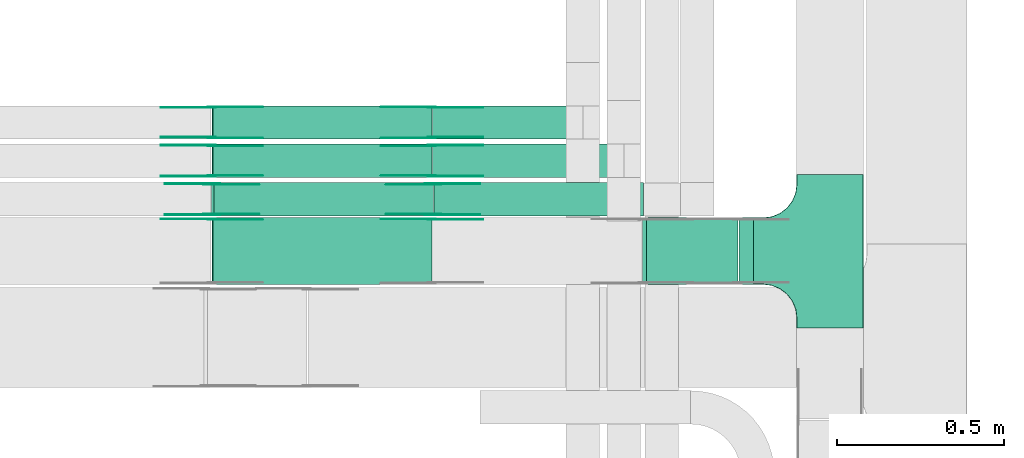
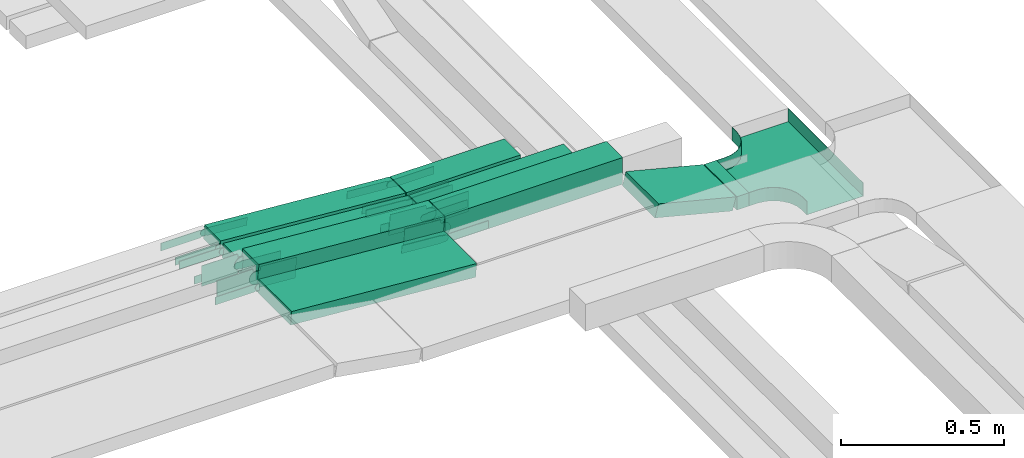
# One storey, part 5 of 19: 29 flow fittings, 9 flow segments.
"""IFC2X3 building model written with IfcOpenShell, lengths in millimetres."""

from ifc_helpers import new_model, entity, si_unit, converted_unit, derived_unit, direction, frame, frame_2d, origin, origin_2d_with_axis, place, context, subcontext, project, spatial, polyline, circle_curve, parameter, trimmed, segment, composite_curve, rectangle, outline, extrude, faceted_brep, source, transform, mapped, material, type_object, type_shapes, element, save


model = new_model("IFC2X3")

# Units and contexts
model_context = context("Model", 3, precision=0.01, world=origin(), true_north=direction((6.12303176911189e-17, 1.0)))
body_context = subcontext(model_context, "Body", "Model", "MODEL_VIEW")
ifc_project = project(units=[si_unit("LENGTHUNIT", "METRE", prefix="MILLI"), si_unit("AREAUNIT", "SQUARE_METRE"), si_unit("VOLUMEUNIT", "CUBIC_METRE"), converted_unit("PLANEANGLEUNIT", "DEGREE", entity("IfcRatioMeasure", 0.0174532925199433), si_unit("PLANEANGLEUNIT", "RADIAN"), dimensions=[0, 0, 0, 0, 0, 0, 0]), si_unit("MASSUNIT", "GRAM", prefix="KILO"), derived_unit("MASSDENSITYUNIT", [(si_unit("MASSUNIT", "GRAM", prefix="KILO"), 1), (si_unit("LENGTHUNIT", "METRE"), -3)]), derived_unit("MOMENTOFINERTIAUNIT", [(si_unit("LENGTHUNIT", "METRE"), 4)]), si_unit("TIMEUNIT", "SECOND"), si_unit("FREQUENCYUNIT", "HERTZ"), si_unit("THERMODYNAMICTEMPERATUREUNIT", "DEGREE_CELSIUS"), derived_unit("THERMALTRANSMITTANCEUNIT", [(si_unit("MASSUNIT", "GRAM", prefix="KILO"), 1), (si_unit("THERMODYNAMICTEMPERATUREUNIT", "KELVIN"), -1), (si_unit("TIMEUNIT", "SECOND"), -3)]), derived_unit("VOLUMETRICFLOWRATEUNIT", [(si_unit("LENGTHUNIT", "METRE"), 3), (si_unit("TIMEUNIT", "SECOND"), -1)]), derived_unit("MASSFLOWRATEUNIT", [(si_unit("MASSUNIT", "GRAM", prefix="KILO"), 1), (si_unit("TIMEUNIT", "SECOND"), -1)]), derived_unit("ROTATIONALFREQUENCYUNIT", [(si_unit("TIMEUNIT", "SECOND"), -1)]), si_unit("ELECTRICCURRENTUNIT", "AMPERE"), si_unit("ELECTRICVOLTAGEUNIT", "VOLT"), si_unit("POWERUNIT", "WATT"), si_unit("FORCEUNIT", "NEWTON", prefix="KILO"), si_unit("ILLUMINANCEUNIT", "LUX"), si_unit("LUMINOUSFLUXUNIT", "LUMEN"), si_unit("LUMINOUSINTENSITYUNIT", "CANDELA"), derived_unit("USERDEFINED", [(si_unit("MASSUNIT", "GRAM", prefix="KILO"), -1), (si_unit("LENGTHUNIT", "METRE"), -2), (si_unit("TIMEUNIT", "SECOND"), 3), (si_unit("LUMINOUSFLUXUNIT", "LUMEN"), 1)]), derived_unit("LINEARVELOCITYUNIT", [(si_unit("LENGTHUNIT", "METRE"), 1), (si_unit("TIMEUNIT", "SECOND"), -1)]), si_unit("PRESSUREUNIT", "PASCAL"), derived_unit("USERDEFINED", [(si_unit("LENGTHUNIT", "METRE"), -2), (si_unit("MASSUNIT", "GRAM", prefix="KILO"), 1), (si_unit("TIMEUNIT", "SECOND"), -2)]), derived_unit("LINEARFORCEUNIT", [(si_unit("MASSUNIT", "GRAM", prefix="KILO"), 1), (si_unit("LENGTHUNIT", "METRE"), 1), (si_unit("TIMEUNIT", "SECOND"), -2), (si_unit("LENGTHUNIT", "METRE"), -1)]), derived_unit("PLANARFORCEUNIT", [(si_unit("MASSUNIT", "GRAM", prefix="KILO"), 1), (si_unit("LENGTHUNIT", "METRE"), 1), (si_unit("TIMEUNIT", "SECOND"), -2), (si_unit("LENGTHUNIT", "METRE"), -2)])], contexts=[model_context])

# Site, building, storey
site_placement = place(None, frame((0.0, -0.00077364408347762, 0.0)))
site = spatial("IfcSite", under=ifc_project, at=site_placement, CompositionType="ELEMENT")
building_placement = place(site_placement, origin())
building = spatial("IfcBuilding", under=site, at=building_placement, CompositionType="ELEMENT")
storey_placement = place(building_placement, frame((0.0, 0.0, 12000.0)))
storey = spatial("IfcBuildingStorey", under=building, at=storey_placement, CompositionType="ELEMENT", Elevation=12000.0)

# Flow segments
cable_carrier_segment_type = type_object("IfcCableCarrierSegmentType", PredefinedType="CABLETRAYSEGMENT")
flow_segment_1_placement = place(storey_placement, frame((16927.6135747369, 12994.157206347, 2800.0)))
element("IfcFlowSegment", 1, at=flow_segment_1_placement, inside=storey, type_object=cable_carrier_segment_type, context=body_context, shape_type="SweptSolid", body=[
    extrude(rectangle(XDim=404.371545128235, YDim=99.9999999999989, at=frame_2d((0.0, 1.08357767203415e-12), x_axis=(1.0, 0.0))), frame((202.185772564118, 50.0, 0.0), z_axis=(0.0, 0.0, 1.0), x_axis=(-1.0, 0.0, 0.0)), (0.0, 0.0, 1.0), 50.0000000000038),
])
flow_segment_2_placement = place(storey_placement, frame((16932.3345533932, 12764.1572065447, 2799.7143217357)))
element("IfcFlowSegment", 2, at=flow_segment_2_placement, inside=storey, type_object=cable_carrier_segment_type, context=body_context, shape_type="SweptSolid", body=[
    extrude(rectangle(XDim=627.939695827148, YDim=99.9999996045748, at=frame_2d((0.0, -1.08357767203415e-12), x_axis=(1.0, 0.0))), frame((314.015310813834, 49.9999998023004, 0.14284181830775), z_axis=(-0.000454953936678616, 0.0, 0.999999896508452), x_axis=(-0.999999896508452, 0.0, -0.000454953936678616)), (0.0, 0.0, 1.0), 99.9999996045756),
])
flow_segment_3_placement = place(storey_placement, frame((16266.5458271958, 12994.157206347, 2800.23031718028)))
element("IfcFlowSegment", 3, at=flow_segment_3_placement, inside=storey, type_object=cable_carrier_segment_type, context=body_context, shape_type="SweptSolid", body=[
    extrude(rectangle(XDim=50.0, YDim=99.9999999999989, at=frame_2d((-2.16360263038951e-12, 0.0), x_axis=(0.0, 1.0))), frame((1.8908897636833, 50.0, 74.6109774865328), z_axis=(0.997135526115965, 0.0, -0.0756355905472889), x_axis=(0.0, 1.0, 0.0)), (0.0, 0.0, 1.0), 656.867870987157),
])
flow_segment_4_placement = place(storey_placement, frame((16927.613574737, 12879.4401033081, 2800.0)))
element("IfcFlowSegment", 4, at=flow_segment_4_placement, inside=storey, type_object=cable_carrier_segment_type, context=body_context, shape_type="SweptSolid", body=[
    extrude(rectangle(XDim=548.189497841086, YDim=99.9999999999989, at=frame_2d((2.1600499167107e-12, -1.08357767203415e-12), x_axis=(1.0, 0.0))), frame((274.094748920545, 50.0, 0.0)), (0.0, 0.0, 1.0), 49.9999999999995),
])
flow_segment_5_placement = place(storey_placement, frame((17845.7963262602, 12558.7956510923, 2727.85030390841)))
element("IfcFlowSegment", 5, at=flow_segment_5_placement, inside=storey, type_object=cable_carrier_segment_type, context=body_context, shape_type="SweptSolid", body=[
    extrude(rectangle(XDim=42.7911006156176, YDim=200.000000000002, at=origin_2d_with_axis()), frame((21.3955503078175, 100.0, 0.0), z_axis=(0.0, 0.0, 1.0), x_axis=(-1.0, 0.0, 0.0)), (0.0, 0.0, 1.0), 49.9999999999995),
])
flow_segment_6_placement = place(storey_placement, frame((17556.1003665916, 12558.7956510923, 2729.76646820147)))
element("IfcFlowSegment", 6, at=flow_segment_6_placement, inside=storey, type_object=cable_carrier_segment_type, context=body_context, shape_type="SweptSolid", body=[
    extrude(rectangle(XDim=50.0000000000006, YDim=199.999999999998, at=origin_2d_with_axis()), frame((6.16822363762218, 100.0, 94.0902542404767), z_axis=(0.969084530600964, 0.0, -0.246728945504798), x_axis=(0.246728945504798, 0.0, 0.969084530600964)), (0.0, 0.0, 1.0), 283.157457802594),
])
flow_segment_7_placement = place(storey_placement, frame((16266.5458271954, 12879.4401033081, 2800.23031718028)))
element("IfcFlowSegment", 7, at=flow_segment_7_placement, inside=storey, type_object=cable_carrier_segment_type, context=body_context, shape_type="SweptSolid", body=[
    extrude(rectangle(XDim=49.9999999999998, YDim=99.9999999999989, at=frame_2d((0.0, 0.0), x_axis=(0.0, 1.0))), frame((1.89088976368114, 50.0, 74.6109774865631), z_axis=(0.997135526115969, 0.0, -0.0756355905472458), x_axis=(0.0, 1.0, 0.0)), (0.0, 0.0, 1.0), 656.867870987572),
])
flow_segment_8_placement = place(storey_placement, frame((16265.5990262702, 12764.157206347, 2800.08739669542)))
element("IfcFlowSegment", 8, at=flow_segment_8_placement, inside=storey, type_object=cable_carrier_segment_type, context=body_context, shape_type="SweptSolid", body=[
    extrude(rectangle(XDim=99.9999999999997, YDim=99.9999999999989, at=frame_2d((0.0, 0.0), x_axis=(0.0, 1.0))), frame((3.78177952736011, 50.0, 99.6822861243202), z_axis=(0.997135526115969, 0.0, -0.0756355905472458), x_axis=(0.0, 1.0, 0.0)), (0.0, 0.0, 1.0), 658.757464019453),
])
flow_segment_9_placement = place(storey_placement, frame((16266.5458271957, 12558.7956510923, 2800.23031718028)))
element("IfcFlowSegment", 9, at=flow_segment_9_placement, inside=storey, type_object=cable_carrier_segment_type, context=body_context, shape_type="SweptSolid", body=[
    extrude(rectangle(XDim=50.0, YDim=199.999999999998, at=frame_2d((0.0, 0.0), x_axis=(0.0, 1.0))), frame((1.89088976368114, 100.0, 74.6109774865458), z_axis=(0.997135526115965, 0.0, -0.0756355905472889), x_axis=(0.0, 1.0, 0.0)), (0.0, 0.0, 1.0), 656.867870987322),
])

# Flow fittings
ifc_material_1 = material(Name="G")
cable_carrier_fitting_type_1 = type_object("IfcCableCarrierFittingType", PredefinedType="NOTDEFINED", material=ifc_material_1)
shared_shape_1 = source(origin(), body_context, "Body", "SweptSolid", [
    extrude(outline(composite_curve([segment(trimmed(circle_curve(frame_2d((-44.5901162790698, 0.0), x_axis=(1.0, 0.0)), 12.5), [parameter(90.0000000000007)], [parameter(270.0)], True, "PARAMETER"), True, "CONTINUOUS"), segment(polyline([(-44.5901162790697, -12.5), (-33.0901162790698, -12.5)]), True, "CONTINUOUS"), segment(polyline([(-33.0901162790698, -12.5), (-31.2296511627907, -14.5)]), True, "CONTINUOUS"), segment(polyline([(-31.2296511627907, -14.5), (108.90988372093, -14.5)]), True, "CONTINUOUS"), segment(polyline([(108.90988372093, -14.5), (108.90988372093, 14.5)]), True, "CONTINUOUS"), segment(polyline([(108.90988372093, 14.5), (-31.2296511627907, 14.5)]), True, "CONTINUOUS"), segment(polyline([(-31.2296511627907, 14.5), (-33.0901162790698, 12.5)]), True, "CONTINUOUS"), segment(polyline([(-33.0901162790698, 12.5), (-44.5901162790699, 12.5)]), True, "CONTINUOUS")], self_intersect=False)), frame((44.5901162790698, 0.0, 0.0), z_axis=(0.0, 0.0, -1.0), x_axis=(1.0, 0.0, 0.0)), (0.0, 0.0, -1.0), 2.0),
])
type_shapes(cable_carrier_fitting_type_1, [shared_shape_1])
for number, where, z_axis, x_axis in (
    (10, (16266.3444383806, 13089.6172063572, 2875.0), (0.0, 1.0, 0.0), (0.997135526115969, 0.0, -0.0756355905472349)),
    (11, (16925.5152856638, 13089.6172063572, 2825.0), (0.0, 1.0, 0.0), (-0.997135526115969, 0.0, 0.0756355905472349)),
    (12, (16925.5152856638, 12883.980103298, 2825.0), (0.0, -1.0, 0.0), (1.0, 0.0, 0.0)),
    (13, (16266.3444383803, 12883.9801032979, 2875.0), (0.0, -1.0, 0.0), (-1.0, 0.0, 0.0)),
    (14, (16925.5152856638, 12754.2556511025, 2825.0), (0.0, 1.0, 0.0), (-0.997135526115969, 0.0, 0.0756355905472349)),
):
    element("IfcFlowFitting", number, at=place(storey_placement, frame(where, z_axis=z_axis, x_axis=x_axis)), inside=storey, type_object=cable_carrier_fitting_type_1, material=ifc_material_1, context=body_context, shape_type="MappedRepresentation", body=[
        mapped(shared_shape_1, transform((0.0, 0.0, 0.0), scale=1.0)),
    ])
cable_carrier_fitting_type_2 = type_object("IfcCableCarrierFittingType", PredefinedType="NOTDEFINED", material=ifc_material_1)
shared_shape_2 = source(origin(), body_context, "Body", "SweptSolid", [
    extrude(outline(composite_curve([segment(trimmed(circle_curve(frame_2d((-44.5901162790697, 0.0), x_axis=(1.0, 0.0)), 12.5), [parameter(90.0000000000007)], [parameter(270.0)], True, "PARAMETER"), True, "CONTINUOUS"), segment(polyline([(-44.5901162790697, -12.5), (-33.0901162790697, -12.5)]), True, "CONTINUOUS"), segment(polyline([(-33.0901162790697, -12.5), (-31.2296511627907, -14.5)]), True, "CONTINUOUS"), segment(polyline([(-31.2296511627907, -14.5), (108.90988372093, -14.5)]), True, "CONTINUOUS"), segment(polyline([(108.90988372093, -14.5), (108.90988372093, 14.5)]), True, "CONTINUOUS"), segment(polyline([(108.90988372093, 14.5), (-31.2296511627907, 14.5)]), True, "CONTINUOUS"), segment(polyline([(-31.2296511627907, 14.5), (-33.0901162790698, 12.5)]), True, "CONTINUOUS"), segment(polyline([(-33.0901162790698, 12.5), (-44.5901162790699, 12.5)]), True, "CONTINUOUS")], self_intersect=False)), frame((44.5901162790697, 0.0, 0.0)), (0.0, 0.0, 1.0), 2.0),
])
type_shapes(cable_carrier_fitting_type_2, [shared_shape_2])
for number, where, z_axis, x_axis in (
    (15, (16266.3444383806, 12998.6972063369, 2875.0), (0.0, -1.0, 0.0), (0.997135526115969, 0.0, -0.0756355905472349)),
    (16, (16925.5152856638, 12998.6972063369, 2825.0), (0.0, -1.0, 0.0), (-0.997135526115969, 0.0, 0.0756355905472349)),
    (17, (16925.5152856638, 12974.9001033183, 2825.0), (0.0, 1.0, 0.0), (1.0, 0.0, 0.0)),
    (18, (16266.3444383803, 12974.9001033183, 2875.0), (0.0, 1.0, 0.0), (-1.0, 0.0, 0.0)),
    (19, (16266.3444383805, 12754.2556511025, 2875.0), (0.0, 1.0, 0.0), (-1.0, 0.0, 0.0)),
):
    element("IfcFlowFitting", number, at=place(storey_placement, frame(where, z_axis=z_axis, x_axis=x_axis)), inside=storey, type_object=cable_carrier_fitting_type_2, material=ifc_material_1, context=body_context, shape_type="MappedRepresentation", body=[
        mapped(shared_shape_2, transform((0.0, 0.0, 0.0), scale=1.0)),
    ])
cable_carrier_fitting_type_3 = type_object("IfcCableCarrierFittingType", PredefinedType="NOTDEFINED", material=ifc_material_1)
shared_shape_3 = source(origin(), body_context, "Body", "SweptSolid", [
    extrude(outline(composite_curve([segment(trimmed(circle_curve(frame_2d((-44.5901162790698, 0.0), x_axis=(1.0, 0.0)), 12.5), [parameter(90.0000000000007)], [parameter(270.0)], True, "PARAMETER"), True, "CONTINUOUS"), segment(polyline([(-44.5901162790697, -12.5), (-33.0901162790698, -12.5)]), True, "CONTINUOUS"), segment(polyline([(-33.0901162790698, -12.5), (-31.2296511627907, -14.5)]), True, "CONTINUOUS"), segment(polyline([(-31.2296511627907, -14.5), (108.90988372093, -14.5)]), True, "CONTINUOUS"), segment(polyline([(108.90988372093, -14.5), (108.90988372093, 14.5)]), True, "CONTINUOUS"), segment(polyline([(108.90988372093, 14.5), (-31.2296511627907, 14.5)]), True, "CONTINUOUS"), segment(polyline([(-31.2296511627907, 14.5), (-33.0901162790698, 12.5)]), True, "CONTINUOUS"), segment(polyline([(-33.0901162790698, 12.5), (-44.5901162790699, 12.5)]), True, "CONTINUOUS")], self_intersect=False)), frame((44.5901162790698, 0.0, 0.0), z_axis=(0.0, 0.0, -1.0), x_axis=(1.0, 0.0, 0.0)), (0.0, 0.0, -1.0), 2.0),
])
type_shapes(cable_carrier_fitting_type_3, [shared_shape_3])
for number, where, z_axis, x_axis in (
    (20, (16266.3444383806, 13000.6972063369, 2875.0), (0.0, -1.0, 0.0), (-1.0, 0.0, 0.0)),
    (21, (16925.5152856638, 13000.6972063369, 2825.0), (0.0, -1.0, 0.0), (1.0, 0.0, 0.0)),
    (22, (16925.5152856639, 12972.9001033183, 2825.0), (0.0, 1.0, 0.0), (-0.99713552611597, 0.0, 0.0756355905472251)),
    (23, (16266.3444383802, 12972.9001033183, 2875.0), (0.0, 1.0, 0.0), (0.99713552611597, 0.0, -0.0756355905472248)),
    (24, (16266.3444383805, 12752.2556511025, 2875.0), (0.0, 1.0, 0.0), (0.99713552611597, 0.0, -0.0756355905472288)),
):
    element("IfcFlowFitting", number, at=place(storey_placement, frame(where, z_axis=z_axis, x_axis=x_axis)), inside=storey, type_object=cable_carrier_fitting_type_3, material=ifc_material_1, context=body_context, shape_type="MappedRepresentation", body=[
        mapped(shared_shape_3, transform((0.0, 0.0, 0.0), scale=1.0)),
    ])
cable_carrier_fitting_type_4 = type_object("IfcCableCarrierFittingType", PredefinedType="NOTDEFINED", material=ifc_material_1)
shared_shape_4 = source(origin(), body_context, "Body", "SweptSolid", [
    extrude(outline(composite_curve([segment(trimmed(circle_curve(frame_2d((-44.5901162790697, 0.0), x_axis=(1.0, 0.0)), 12.5), [parameter(90.0000000000007)], [parameter(270.0)], True, "PARAMETER"), True, "CONTINUOUS"), segment(polyline([(-44.5901162790697, -12.5), (-33.0901162790697, -12.5)]), True, "CONTINUOUS"), segment(polyline([(-33.0901162790697, -12.5), (-31.2296511627907, -14.5)]), True, "CONTINUOUS"), segment(polyline([(-31.2296511627907, -14.5), (108.90988372093, -14.5)]), True, "CONTINUOUS"), segment(polyline([(108.90988372093, -14.5), (108.90988372093, 14.5)]), True, "CONTINUOUS"), segment(polyline([(108.90988372093, 14.5), (-31.2296511627907, 14.5)]), True, "CONTINUOUS"), segment(polyline([(-31.2296511627907, 14.5), (-33.0901162790698, 12.5)]), True, "CONTINUOUS"), segment(polyline([(-33.0901162790698, 12.5), (-44.5901162790699, 12.5)]), True, "CONTINUOUS")], self_intersect=False)), frame((44.5901162790697, 0.0, 0.0)), (0.0, 0.0, 1.0), 2.0),
])
type_shapes(cable_carrier_fitting_type_4, [shared_shape_4])
for number, where, z_axis, x_axis in (
    (25, (16266.3444383806, 13087.6172063572, 2875.0), (0.0, 1.0, 0.0), (-1.0, 0.0, 0.0)),
    (26, (16925.5152856638, 13087.6172063572, 2825.0), (0.0, 1.0, 0.0), (1.0, 0.0, 0.0)),
    (27, (16925.5152856639, 12885.980103298, 2825.0), (0.0, -1.0, 0.0), (-0.99713552611597, 0.0, 0.0756355905472251)),
    (28, (16266.3444383802, 12885.980103298, 2875.0), (0.0, -1.0, 0.0), (0.99713552611597, 0.0, -0.0756355905472248)),
    (29, (16925.5152856638, 12752.2556511025, 2825.0), (0.0, 1.0, 0.0), (1.0, 0.0, 0.0)),
):
    element("IfcFlowFitting", number, at=place(storey_placement, frame(where, z_axis=z_axis, x_axis=x_axis)), inside=storey, type_object=cable_carrier_fitting_type_4, material=ifc_material_1, context=body_context, shape_type="MappedRepresentation", body=[
        mapped(shared_shape_4, transform((0.0, 0.0, 0.0), scale=1.0)),
    ])
ifc_material_2 = material()
cable_carrier_fitting_type_5 = type_object("IfcCableCarrierFittingType", PredefinedType="NOTDEFINED", material=ifc_material_2)
shared_shape_5 = source(origin(), body_context, "Body", "Brep", [
    faceted_brep([(-103.407417371087, -174.118095489753, 25.0), (-100.0, -200.0, 25.0), (-100.0, -230.0, 25.0), (-99.1999999999932, -230.0, 25.0), (-99.1999999999933, -200.0, 25.0), (-102.634676710055, -173.911040253671, 25.0), (-112.704639298522, -149.600000000004, 25.0), (-128.723636456391, -128.7236364564, 25.0), (-149.599999999996, -112.704639298532, 25.0), (-173.911040253663, -102.634676710066, 25.0), (-200.0, -99.2000000000044, 25.0), (-230.0, -99.2000000000044, 25.0), (-230.0, -100.0, 25.0), (-200.0, -100.0, 25.0), (-174.118095489746, -103.407417371099, 25.0), (-150.0, -113.397459621561, 25.0), (-129.28932188134, -129.28932188135, 25.0), (-113.39745962155, -150.0, 25.0), (230.0, -100.0, 25.0), (230.0, -99.2000000000044, 25.0), (200.0, -99.2000000000097, 25.0), (173.911040253722, -102.634676710071, 25.0), (149.60000000005, -112.704639298537, 25.0), (128.723636456439, -128.723636456403, 25.0), (112.704639298563, -149.600000000006, 25.0), (102.634676710086, -173.911040253673, 25.0), (99.2000000000121, -200.0, 25.0), (99.2000000000069, -230.0, 25.0), (100.0, -230.0, 25.0), (100.0, -200.0, 25.0), (103.407417371119, -174.118095489755, 25.0), (113.397459621593, -150.0, 25.0), (129.289321881391, -129.289321881354, 25.0), (150.0, -113.397459621567, 25.0), (174.118095489805, -103.407417371105, 25.0), (200.0, -100.0, 25.0), (230.0, 99.1999999999954, 25.0), (230.0, 100.0, 25.0), (-230.0, 100.0, 25.0), (-230.0, 99.1999999999954, 25.0), (-230.0, -100.0, -25.0), (-230.0, 100.0, -25.0), (230.0, 100.0, -25.0), (230.0, -100.0, -25.0), (200.0, -100.0, -25.0), (174.118095489805, -103.407417371105, -25.0), (150.0, -113.397459621567, -25.0), (129.289321881391, -129.289321881354, -25.0), (113.397459621593, -150.0, -25.0), (103.407417371119, -174.118095489755, -25.0), (100.0, -200.0, -25.0), (100.0, -230.0, -25.0), (-100.0, -230.0, -25.0), (-100.0, -200.0, -25.0), (-103.407417371087, -174.118095489753, -25.0), (-113.39745962155, -150.0, -25.0), (-129.28932188134, -129.28932188135, -25.0), (-150.0, -113.397459621561, -25.0), (-174.118095489746, -103.407417371099, -25.0), (-200.0, -100.0, -25.0), (-100.0, -200.0, -24.199999999986), (99.2000000000069, -230.0, -24.199999999986), (-99.1999999999932, -230.0, -24.199999999986), (-99.1999999999933, -200.0, -24.199999999986), (-200.0, -99.2000000000044, -24.199999999986), (-230.0, -99.2000000000044, -24.199999999986), (230.0, -99.2000000000044, -24.199999999986), (200.0, -99.2000000000044, -24.199999999986), (-230.0, 99.1999999999954, -24.199999999986), (-200.0, -100.0, -24.199999999986), (200.0, -100.0, -24.199999999986), (230.0, 99.1999999999954, -24.199999999986), (99.2000000000121, -200.0, -24.199999999986), (100.0, -200.0, -24.199999999986), (-173.911040253663, -102.634676710066, -24.199999999986), (-149.599999999996, -112.704639298532, -24.199999999986), (-128.723636456391, -128.7236364564, -24.199999999986), (-112.704639298522, -149.600000000004, -24.199999999986), (-102.634676710055, -173.911040253671, -24.199999999986), (102.634676710086, -173.911040253674, -24.199999999986), (112.704639298563, -149.600000000007, -24.199999999986), (128.723636456439, -128.723636456403, -24.199999999986), (149.60000000005, -112.704639298537, -24.199999999986), (173.911040253721, -102.634676710071, -24.199999999986)], [[[0, 1, 2, 3, 4, 5, 6, 7, 8, 9, 10, 11, 12, 13, 14, 15, 16, 17]], [[18, 19, 20, 21, 22, 23, 24, 25, 26, 27, 28, 29, 30, 31, 32, 33, 34, 35]], [[36, 37, 38, 39]], [[40, 41, 42, 43, 44, 45, 46, 47, 48, 49, 50, 51, 52, 53, 54, 55, 56, 57, 58, 59]], [[2, 1, 60, 53, 52]], [[3, 2, 52, 51, 28, 27, 61, 62]], [[4, 3, 62, 63]], [[11, 10, 64, 65]], [[20, 19, 66, 67]], [[39, 38, 41, 40, 12, 11, 65, 68]], [[13, 12, 40, 59, 69]], [[18, 35, 70, 44, 43]], [[19, 18, 43, 42, 37, 36, 71, 66]], [[27, 26, 72, 61]], [[29, 28, 51, 50, 73]], [[38, 37, 42, 41]], [[36, 39, 68, 71]], [[68, 65, 64, 74, 75, 76, 77, 78, 63, 62, 61, 72, 79, 80, 81, 82, 83, 67, 66, 71]], [[14, 13, 69, 59, 58]], [[58, 57, 15, 14]], [[15, 57, 56, 16]], [[0, 17, 55, 54]], [[0, 54, 53, 60, 1]], [[55, 17, 16, 56]], [[5, 4, 63, 78]], [[6, 5, 78, 77]], [[7, 6, 77, 76]], [[8, 7, 76, 75]], [[9, 8, 75, 74]], [[10, 9, 74, 64]], [[21, 20, 67, 83]], [[22, 21, 83, 82]], [[23, 22, 82, 81]], [[81, 80, 24, 23]], [[24, 80, 79, 25]], [[79, 72, 26, 25]], [[30, 29, 73, 50, 49]], [[31, 30, 49, 48]], [[31, 48, 47, 32]], [[33, 32, 47, 46]], [[45, 34, 33, 46]], [[34, 45, 44, 70, 35]]]),
])
type_shapes(cable_carrier_fitting_type_5, [shared_shape_5])
flow_fitting_placement = place(storey_placement, frame((18118.5874268759, 12658.7956510924, 2752.85030390842), z_axis=(0.0, 0.0, 1.0), x_axis=(0.0, -1.0, 0.0)))
element("IfcFlowFitting", 30, at=flow_fitting_placement, inside=storey, type_object=cable_carrier_fitting_type_5, material=ifc_material_2, Name="470_DKC_S5_T", context=body_context, shape_type="MappedRepresentation", body=[
    mapped(shared_shape_5, transform((0.0, 0.0, 0.0), scale=1.0)),
])
cable_carrier_fitting_type_6 = type_object("IfcCableCarrierFittingType", PredefinedType="NOTDEFINED", material=ifc_material_1)
shared_shape_6 = source(origin(), body_context, "Body", "SweptSolid", [
    extrude(outline(composite_curve([segment(trimmed(circle_curve(frame_2d((-41.4651162790697, 0.0), x_axis=(1.0, 0.0)), 25.0), [parameter(90.0000000000007)], [parameter(270.0)], True, "PARAMETER"), True, "CONTINUOUS"), segment(polyline([(-41.4651162790697, -25.0), (-29.9651162790697, -25.0)]), True, "CONTINUOUS"), segment(polyline([(-29.9651162790697, -25.0), (-28.1046511627907, -38.5)]), True, "CONTINUOUS"), segment(polyline([(-28.1046511627907, -38.5), (99.5348837209303, -38.5)]), True, "CONTINUOUS"), segment(polyline([(99.5348837209303, -38.5), (99.5348837209303, 38.5)]), True, "CONTINUOUS"), segment(polyline([(99.5348837209303, 38.5), (-28.1046511627907, 38.5)]), True, "CONTINUOUS"), segment(polyline([(-28.1046511627907, 38.5), (-29.9651162790697, 25.0)]), True, "CONTINUOUS"), segment(polyline([(-29.9651162790697, 25.0), (-41.46511627907, 25.0)]), True, "CONTINUOUS")], self_intersect=False)), frame((41.4651162790697, 0.0, 0.0), z_axis=(0.0, 0.0, -1.0), x_axis=(1.0, 0.0, 0.0)), (0.0, 0.0, -1.0), 2.0),
])
type_shapes(cable_carrier_fitting_type_6, [shared_shape_6])
for number, where, z_axis, x_axis in (
    (31, (16929.2999099268, 12768.6972063369, 2849.71292539111), (0.0, -1.0, 0.0), (0.999999896508455, 0.0, 0.000454953931720556)),
    (32, (16266.3444383803, 12768.6972063369, 2900.0), (0.0, -1.0, 0.0), (-1.0, 0.0, 0.0)),
):
    element("IfcFlowFitting", number, at=place(storey_placement, frame(where, z_axis=z_axis, x_axis=x_axis)), inside=storey, type_object=cable_carrier_fitting_type_6, material=ifc_material_1, context=body_context, shape_type="MappedRepresentation", body=[
        mapped(shared_shape_6, transform((0.0, 0.0, 0.0), scale=1.0)),
    ])
cable_carrier_fitting_type_7 = type_object("IfcCableCarrierFittingType", PredefinedType="NOTDEFINED", material=ifc_material_1)
shared_shape_7 = source(origin(), body_context, "Body", "SweptSolid", [
    extrude(outline(composite_curve([segment(trimmed(circle_curve(frame_2d((-41.4651162790697, 0.0), x_axis=(1.0, 0.0)), 25.0), [parameter(90.0000000000007)], [parameter(270.0)], True, "PARAMETER"), True, "CONTINUOUS"), segment(polyline([(-41.4651162790697, -25.0), (-29.9651162790697, -25.0)]), True, "CONTINUOUS"), segment(polyline([(-29.9651162790697, -25.0), (-28.1046511627907, -38.5)]), True, "CONTINUOUS"), segment(polyline([(-28.1046511627907, -38.5), (99.5348837209303, -38.5)]), True, "CONTINUOUS"), segment(polyline([(99.5348837209303, -38.5), (99.5348837209303, 38.5)]), True, "CONTINUOUS"), segment(polyline([(99.5348837209303, 38.5), (-28.1046511627907, 38.5)]), True, "CONTINUOUS"), segment(polyline([(-28.1046511627907, 38.5), (-29.9651162790697, 25.0)]), True, "CONTINUOUS"), segment(polyline([(-29.9651162790697, 25.0), (-41.46511627907, 25.0)]), True, "CONTINUOUS")], self_intersect=False)), frame((41.4651162790697, 0.0, 0.0)), (0.0, 0.0, 1.0), 2.0),
])
type_shapes(cable_carrier_fitting_type_7, [shared_shape_7])
for number, where, z_axis, x_axis in (
    (33, (16929.2999099268, 12859.6172063572, 2849.71292539111), (0.0, 1.0, 0.0), (0.999999896508455, 0.0, 0.000454953931720556)),
    (34, (16266.3444383803, 12859.6172063572, 2900.0), (0.0, 1.0, 0.0), (-1.0, 0.0, 0.0)),
):
    element("IfcFlowFitting", number, at=place(storey_placement, frame(where, z_axis=z_axis, x_axis=x_axis)), inside=storey, type_object=cable_carrier_fitting_type_7, material=ifc_material_1, context=body_context, shape_type="MappedRepresentation", body=[
        mapped(shared_shape_7, transform((0.0, 0.0, 0.0), scale=1.0)),
    ])
cable_carrier_fitting_type_8 = type_object("IfcCableCarrierFittingType", PredefinedType="NOTDEFINED", material=ifc_material_1)
shared_shape_8 = source(origin(), body_context, "Body", "SweptSolid", [
    extrude(outline(composite_curve([segment(trimmed(circle_curve(frame_2d((-41.4651162790697, 0.0), x_axis=(1.0, 0.0)), 25.0), [parameter(90.0000000000007)], [parameter(270.0)], True, "PARAMETER"), True, "CONTINUOUS"), segment(polyline([(-41.4651162790697, -25.0), (-29.9651162790697, -25.0)]), True, "CONTINUOUS"), segment(polyline([(-29.9651162790697, -25.0), (-28.1046511627907, -38.5)]), True, "CONTINUOUS"), segment(polyline([(-28.1046511627907, -38.5), (99.5348837209303, -38.5)]), True, "CONTINUOUS"), segment(polyline([(99.5348837209303, -38.5), (99.5348837209303, 38.5)]), True, "CONTINUOUS"), segment(polyline([(99.5348837209303, 38.5), (-28.1046511627907, 38.5)]), True, "CONTINUOUS"), segment(polyline([(-28.1046511627907, 38.5), (-29.9651162790697, 25.0)]), True, "CONTINUOUS"), segment(polyline([(-29.9651162790697, 25.0), (-41.46511627907, 25.0)]), True, "CONTINUOUS")], self_intersect=False)), frame((41.4651162790697, 0.0, 0.0), z_axis=(0.0, 0.0, -1.0), x_axis=(1.0, 0.0, 0.0)), (0.0, 0.0, -1.0), 2.0),
])
type_shapes(cable_carrier_fitting_type_8, [shared_shape_8])
for number, where, z_axis, x_axis in (
    (35, (16929.2999099269, 12857.6172063572, 2849.71292539111), (0.0, 1.0, 0.0), (-0.99713552611597, 0.0, 0.0756355905472225)),
    (36, (16266.3444383802, 12857.6172063572, 2900.0), (0.0, 1.0, 0.0), (0.99713552611597, 0.0, -0.0756355905472226)),
):
    element("IfcFlowFitting", number, at=place(storey_placement, frame(where, z_axis=z_axis, x_axis=x_axis)), inside=storey, type_object=cable_carrier_fitting_type_8, material=ifc_material_1, context=body_context, shape_type="MappedRepresentation", body=[
        mapped(shared_shape_8, transform((0.0, 0.0, 0.0), scale=1.0)),
    ])
cable_carrier_fitting_type_9 = type_object("IfcCableCarrierFittingType", PredefinedType="NOTDEFINED", material=ifc_material_1)
shared_shape_9 = source(origin(), body_context, "Body", "SweptSolid", [
    extrude(outline(composite_curve([segment(trimmed(circle_curve(frame_2d((-41.4651162790697, 0.0), x_axis=(1.0, 0.0)), 25.0), [parameter(90.0000000000007)], [parameter(270.0)], True, "PARAMETER"), True, "CONTINUOUS"), segment(polyline([(-41.4651162790697, -25.0), (-29.9651162790697, -25.0)]), True, "CONTINUOUS"), segment(polyline([(-29.9651162790697, -25.0), (-28.1046511627907, -38.5)]), True, "CONTINUOUS"), segment(polyline([(-28.1046511627907, -38.5), (99.5348837209303, -38.5)]), True, "CONTINUOUS"), segment(polyline([(99.5348837209303, -38.5), (99.5348837209303, 38.5)]), True, "CONTINUOUS"), segment(polyline([(99.5348837209303, 38.5), (-28.1046511627907, 38.5)]), True, "CONTINUOUS"), segment(polyline([(-28.1046511627907, 38.5), (-29.9651162790697, 25.0)]), True, "CONTINUOUS"), segment(polyline([(-29.9651162790697, 25.0), (-41.46511627907, 25.0)]), True, "CONTINUOUS")], self_intersect=False)), frame((41.4651162790697, 0.0, 0.0)), (0.0, 0.0, 1.0), 2.0),
])
type_shapes(cable_carrier_fitting_type_9, [shared_shape_9])
for number, where, z_axis, x_axis in (
    (37, (16929.2999099269, 12770.6972063369, 2849.71292539111), (0.0, -1.0, 0.0), (-0.99713552611597, 0.0, 0.0756355905472225)),
    (38, (16266.3444383802, 12770.6972063369, 2900.0), (0.0, -1.0, 0.0), (0.99713552611597, 0.0, -0.0756355905472226)),
):
    element("IfcFlowFitting", number, at=place(storey_placement, frame(where, z_axis=z_axis, x_axis=x_axis)), inside=storey, type_object=cable_carrier_fitting_type_9, material=ifc_material_1, context=body_context, shape_type="MappedRepresentation", body=[
        mapped(shared_shape_9, transform((0.0, 0.0, 0.0), scale=1.0)),
    ])

save(model, "model.ifc")
